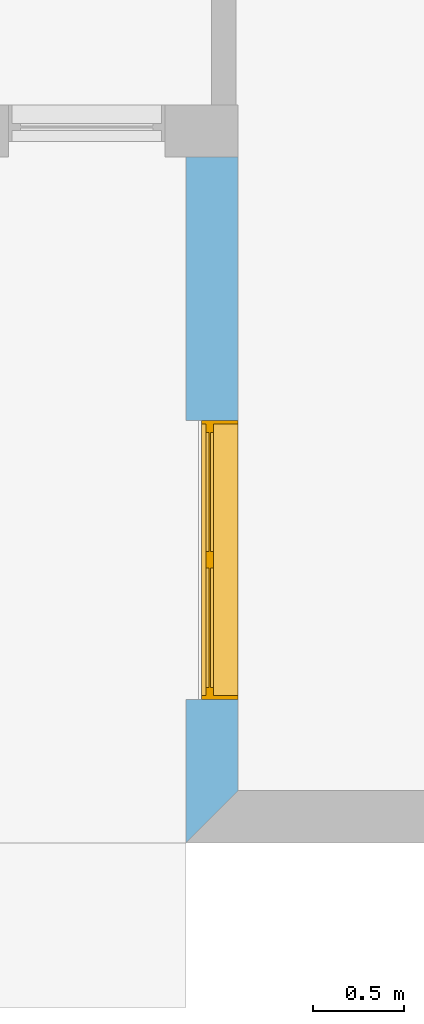
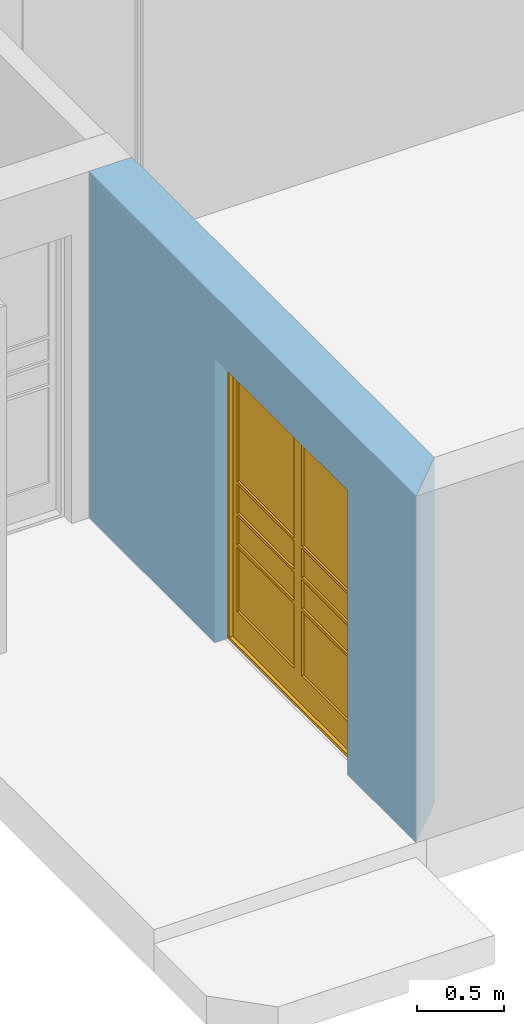
# One storey, part 8 of 15: 1 window, 1 opening, plus 1 element that does not belong to this part.
"""IFC4 building model written with IfcOpenShell, lengths in millimetres."""

from ifc_helpers import new_model, entity, si_unit, converted_unit, frame, origin_with_axes, origin_2d_with_axis, place, context, subcontext, project, spatial, line, indexed_curve, outline, extrude, clip, halfspace, polygons, source, transform, mapped, material, layer, layer_set, layer_usage, type_object, type_shapes, element, fill, save


model = new_model("IFC4")

# Units and contexts
model_context = context("Model", 3, precision=1e-05, world=origin_with_axes())
plan_context = context("Plan", 2, precision=1e-05, world=origin_2d_with_axis())
body_context = subcontext(model_context, "Body", "Model", "MODEL_VIEW")
ifc_project = project(units=[si_unit("VOLUMEUNIT", "CUBIC_METRE"), si_unit("LENGTHUNIT", "METRE", prefix="MILLI"), converted_unit("PLANEANGLEUNIT", "degree", entity("IfcReal", 0.0174532925199433), si_unit("PLANEANGLEUNIT", "RADIAN"), dimensions=[0, 0, 0, 0, 0, 0, 0]), si_unit("AREAUNIT", "SQUARE_METRE")], contexts=[model_context, plan_context])

# Site, building, storey
site_placement = place(None, origin_with_axes())
site = spatial("IfcSite", under=ifc_project, at=site_placement)
building_placement = place(site_placement, origin_with_axes())
building = spatial("IfcBuilding", under=site, at=building_placement, Name="Building")
storey_placement = place(building_placement, origin_with_axes())
storey = spatial("IfcBuildingStorey", under=building, at=storey_placement, Name="EXISTING")

# Wall, opening, window
ifc_material = material()
ifc_layer = layer(ifc_material, 285.0, Name="brick")
ifc_layer_set = layer_set([ifc_layer])
ifc_layer_usage = layer_usage(ifc_layer_set, "AXIS2", "POSITIVE", 0.0)
wall_type = type_object("IfcWallType", Name="285mm Wall", PredefinedType="STANDARD", material=ifc_layer_set)
wall_placement = place(storey_placement, frame((5879.11891937256, -4518.33343505859, 0.0), z_axis=(0.0, 0.0, 1.0), x_axis=(3.13916473260163e-07, 0.999999999999951, 0.0)))
wall = element("IfcWall", 1, at=wall_placement, inside=storey, type_object=wall_type, material=ifc_layer_usage, Name="Wall", context=body_context, shape_type="Clipping", body=[
    clip(extrude(outline(indexed_curve([(0.0, 0.0), (0.0, 285.0), (3750.00025431326, 285.0), (3750.00025431326, 0.0), (0.0, 0.0)], self_intersect=False)), origin_with_axes(), (0.0, 0.0, 1.0), 2425.00019073486), halfspace(frame((285.000115633011, -0.000329928298015147, 0.0), z_axis=(-0.707106828689575, -0.707106709480286, 0.0), x_axis=(-0.707106721581899, 0.707106840791191, 0.0)), False)),
])
shared_shape_1 = source(origin_with_axes(), body_context, "Body", "SweptSolid", [
    extrude(outline(indexed_curve([(0.0, 0.0), (1525.00061035156, 0.0), (1525.00061035156, 1989.99975585938), (0.0, 1989.99975585938)], segments=[line(1, 2, 3, 4, 1)])), frame((-3.27825517842939e-07, -600.0, 0.0), z_axis=(0.0, -1.0, 0.0), x_axis=(1.0, 0.0, 0.0)), (0.0, 0.0, -1.0), 1200.0),
])
opening_placement = place(wall_placement, frame((785.000324249383, -0.000230412628532406, 0.0), z_axis=(0.0, 0.0, 1.0), x_axis=(1.0, -5.29395592033938e-23, 0.0)))
opening = element("IfcOpeningElement", 2, at=opening_placement, cuts=wall, PredefinedType="OPENING", context=body_context, shape_type="MappedRepresentation", body=[
    mapped(shared_shape_1, transform((0.0, 0.0, 0.0), x_axis=(1.0, 0.0, 0.0), y_axis=(0.0, 1.0, 0.0), z_axis=(0.0, 0.0, 1.0), scale=1.0)),
])
window_type = type_object("IfcWindowType", Name="Ex.1525x1990", PartitioningType="NOTDEFINED", PredefinedType="WINDOW")
shared_shape_2 = source(origin_with_axes(), body_context, "Body", "Tessellation", [
    polygons([(1525.00012207031, -146.538314819336, 0.0), (1525.00012207031, -146.538314819336, 19.999979019165), (0.000149011597386561, -146.538543701172, 0.0), (0.000149011597386561, -146.538543701172, 19.999979019165), (1525.00012207031, 53.4614906311035, 0.0), (1525.00012207031, 53.4614906311035, 19.999979019165), (0.000149011597386561, 53.4614906311035, 0.0), (0.000149011597386561, 53.4614906311035, 19.999979019165), (-0.000327825517160818, -146.538314819336, 19.999979019165), (19.9996509552002, -146.538314819336, 19.999979019165), (-0.000327825517160818, -146.538543701172, 1969.99987792969), (19.9996509552002, -146.538543701172, 1969.99987792969), (-0.000327825517160818, 53.4614906311035, 19.999979019165), (19.9996509552002, 53.4614906311035, 19.999979019165), (-0.000327825517160818, 53.4614906311035, 1969.99987792969), (19.9996509552002, 53.4614906311035, 1969.99987792969), (1505.00036621094, -146.538314819336, 19.999979019165), (1525.00036621094, -146.538314819336, 19.999979019165), (1504.99987792969, -146.538543701172, 1969.99987792969), (1525.00012207031, -146.538543701172, 1969.99987792969), (1505.00012207031, 53.4614906311035, 19.999979019165), (1525.00036621094, 53.4614906311035, 19.999979019165), (1504.99987792969, 53.4614906311035, 1969.99987792969), (1524.99987792969, 53.4614906311035, 1969.99987792969), (1525.00012207031, -146.538314819336, 1969.99987792969), (1525.00012207031, -146.538314819336, 1989.99987792969), (0.000149011597386561, -146.538543701172, 1969.99987792969), (0.000149011597386561, -146.538543701172, 1989.99987792969), (1525.00012207031, 53.4614906311035, 1969.99987792969), (1525.00012207031, 53.4614906311035, 1989.99987792969), (0.000149011597386561, 53.4614906311035, 1969.99987792969), (0.000149011597386561, 53.4614906311035, 1989.99987792969), (64.9987716674805, -11.5385608673096, 1925.00061035156), (19.999174118042, -11.5385608673096, 1925.00061035156), (64.9987716674805, -11.5385608673096, 220.002517700195), (19.999174118042, -11.5383224487305, 220.002517700195), (64.9987716674805, 28.4616374969482, 1925.00061035156), (19.999174118042, 28.4616374969482, 1925.00061035156), (64.9987716674805, 28.4616374969482, 220.002517700195), (19.999174118042, 28.4616374969482, 220.002517700195), (762.499389648438, -11.5383224487305, 20.0024242401123), (762.499389648438, -11.5383224487305, 220.001449584961), (20.0001277923584, -11.5383224487305, 20.0034370422363), (20.0001277923584, -11.5383224487305, 220.002395629883), (762.499389648438, 28.4616374969482, 20.0024242401123), (762.499389648438, 28.4616374969482, 220.001449584961), (20.0001277923584, 28.4616374969482, 20.0034370422363), (20.0001277923584, 28.4616374969482, 220.002395629883), (1504.99987792969, -11.5385608673096, 1925.00036621094), (1460.00048828125, -11.5385608673096, 1925.00036621094), (1504.99963378906, -11.5385608673096, 220.00227355957), (1460.00036621094, -11.5383224487305, 220.00227355957), (1504.99987792969, 28.4616374969482, 1925.00036621094), (1460.00048828125, 28.4616374969482, 1925.00036621094), (1504.99963378906, 28.4616374969482, 220.00227355957), (1460.00036621094, 28.4616374969482, 220.00227355957), (762.499389648438, -11.5385608673096, 1925.00036621094), (717.499816894531, -11.5385608673096, 1925.00036621094), (762.499389648438, -11.5385608673096, 220.002395629883), (717.499816894531, -11.5383224487305, 220.002395629883), (762.499389648438, 28.4616374969482, 1925.00036621094), (717.499816894531, 28.4616374969482, 1925.00036621094), (762.499389648438, 28.4616374969482, 220.002395629883), (717.499816894531, 28.4616374969482, 220.002395629883), (807.499450683594, -11.5385608673096, 1925.00036621094), (762.500366210938, -11.5385608673096, 1925.00036621094), (807.499450683594, -11.5385608673096, 220.002395629883), (762.500366210938, -11.5383224487305, 220.002395629883), (807.499450683594, 28.4616374969482, 1925.00036621094), (762.500366210938, 28.4616374969482, 1925.00036621094), (807.499450683594, 28.4616374969482, 220.002395629883), (762.500366210938, 28.4616374969482, 220.002395629883), (1504.99963378906, -11.5383224487305, 20.0024242401123), (1504.99963378906, -11.5383224487305, 220.001449584961), (762.500854492188, -11.5383224487305, 20.0034370422363), (762.500854492188, -11.5383224487305, 220.002395629883), (1504.99963378906, 28.4616374969482, 20.0024242401123), (1504.99963378906, 28.4616374969482, 220.001449584961), (762.500854492188, 28.4616374969482, 20.0034370422363), (762.500854492188, 28.4616374969482, 220.002395629883), (762.499389648438, -11.5383224487305, 1924.99938964844), (762.499389648438, -11.5383224487305, 1969.99890136719), (20.0001277923584, -11.5383224487305, 1925.00036621094), (20.0001277923584, -11.5383224487305, 1969.99987792969), (762.499389648438, 28.4616374969482, 1924.99938964844), (762.499389648438, 28.4616374969482, 1969.99890136719), (20.0001277923584, 28.4616374969482, 1925.00036621094), (20.0001277923584, 28.4616374969482, 1969.99987792969), (1504.99963378906, -11.5383224487305, 1924.99938964844), (1504.99963378906, -11.5383224487305, 1969.99890136719), (762.500854492188, -11.5383224487305, 1925.00036621094), (762.500854492188, -11.5383224487305, 1969.99987792969), (1504.99963378906, 28.4616374969482, 1924.99938964844), (1504.99963378906, 28.4616374969482, 1969.99890136719), (762.500854492188, 28.4616374969482, 1925.00036621094), (762.500854492188, 28.4616374969482, 1969.99987792969), (717.499816894531, -11.5383224487305, 1110.00158691406), (717.499816894531, -11.5383224487305, 1130.00109863281), (64.9987716674805, -11.5383224487305, 1110.001953125), (64.9987716674805, -11.5383224487305, 1130.00158691406), (717.499816894531, 28.4616374969482, 1110.00158691406), (717.499816894531, 28.4616374969482, 1130.00109863281), (64.9987716674805, 28.4616374969482, 1110.001953125), (64.9987716674805, 28.4616374969482, 1130.00158691406), (1460.00036621094, -11.5383224487305, 1110.00158691406), (1460.00036621094, -11.5383224487305, 1130.00109863281), (807.4990234375, -11.5383224487305, 1110.001953125), (807.4990234375, -11.5383224487305, 1130.00158691406), (1460.00036621094, 28.4616374969482, 1110.00158691406), (1460.00036621094, 28.4616374969482, 1130.00109863281), (807.4990234375, 28.4616374969482, 1110.001953125), (807.4990234375, 28.4616374969482, 1130.00158691406), (717.499816894531, -11.5383224487305, 890.001708984375), (717.499816894531, -11.5383224487305, 910.001220703125), (64.9987716674805, -11.5383224487305, 890.001953125), (64.9987716674805, -11.5383224487305, 910.001708984375), (717.499816894531, 28.4616374969482, 890.001708984375), (717.499816894531, 28.4616374969482, 910.001220703125), (64.9987716674805, 28.4616374969482, 890.001953125), (64.9987716674805, 28.4616374969482, 910.001708984375), (1460.00036621094, -11.5383224487305, 890.001708984375), (1460.00036621094, -11.5383224487305, 910.001220703125), (807.4990234375, -11.5383224487305, 890.001953125), (807.4990234375, -11.5383224487305, 910.001708984375), (1460.00036621094, 28.4616374969482, 890.001708984375), (1460.00036621094, 28.4616374969482, 910.001220703125), (807.4990234375, 28.4616374969482, 890.001953125), (807.4990234375, 28.4616374969482, 910.001708984375), (717.499816894531, -11.5383224487305, 670.001586914062), (717.499816894531, -11.5383224487305, 690.001159667969), (64.9987716674805, -11.5383224487305, 670.002014160156), (64.9987716674805, -11.5383224487305, 690.001586914062), (717.499816894531, 28.4616374969482, 670.001586914062), (717.499816894531, 28.4616374969482, 690.001159667969), (64.9987716674805, 28.4616374969482, 670.002014160156), (64.9987716674805, 28.4616374969482, 690.001586914062), (1460.00036621094, -11.5383224487305, 670.001586914062), (1460.00036621094, -11.5383224487305, 690.001159667969), (807.4990234375, -11.5383224487305, 670.002014160156), (807.4990234375, -11.5383224487305, 690.001586914062), (1460.00036621094, 28.4616374969482, 670.001586914062), (1460.00036621094, 28.4616374969482, 690.001159667969), (807.4990234375, 28.4616374969482, 670.002014160156), (807.4990234375, 28.4616374969482, 690.001586914062), (717.499328613281, 3.4615433216095, 1925.00036621094), (64.9987716674805, 3.4615433216095, 1925.00036621094), (717.499328613281, 3.4615433216095, 1130.00122070312), (64.9987716674805, 3.4615433216095, 1130.00122070312), (717.499328613281, 13.4615335464478, 1925.00036621094), (64.9987716674805, 13.4615335464478, 1925.00036621094), (717.499328613281, 13.4615335464478, 1130.00122070312), (64.9987716674805, 13.4615335464478, 1130.00122070312), (717.499328613281, 3.4615433216095, 670.001831054688), (64.9987716674805, 3.4615433216095, 670.001831054688), (717.499328613281, 3.4615433216095, 220.001983642578), (64.9987716674805, 3.4615433216095, 220.002044677734), (717.499328613281, 13.4615335464478, 670.001831054688), (64.9987716674805, 13.4615335464478, 670.001831054688), (717.499328613281, 13.4615335464478, 220.001983642578), (64.9987716674805, 13.4615335464478, 220.002044677734), (717.499328613281, 3.4615433216095, 1110.00158691406), (64.9987716674805, 3.4615433216095, 1110.00158691406), (717.499328613281, 3.4615433216095, 910.001220703125), (64.9987716674805, 3.4615433216095, 910.001220703125), (717.499328613281, 13.4615335464478, 1110.00158691406), (64.9987716674805, 13.4615335464478, 1110.00158691406), (717.499328613281, 13.4615335464478, 910.001220703125), (64.9987716674805, 13.4615335464478, 910.001220703125), (717.499328613281, 3.4615433216095, 890.002197265625), (64.9987716674805, 3.4615433216095, 890.002197265625), (717.499328613281, 3.4615433216095, 690.001831054688), (64.9987716674805, 3.4615433216095, 690.001831054688), (717.499328613281, 13.4615335464478, 890.002197265625), (64.9987716674805, 13.4615335464478, 890.002197265625), (717.499328613281, 13.4615335464478, 690.001831054688), (64.9987716674805, 13.4615335464478, 690.001831054688), (1459.99987792969, 3.4615433216095, 1925.00036621094), (807.499450683594, 3.4615433216095, 1925.00036621094), (1459.99987792969, 3.4615433216095, 1130.00122070312), (807.4990234375, 3.4615433216095, 1130.00122070312), (1459.99987792969, 13.4615335464478, 1925.00036621094), (807.499450683594, 13.4615335464478, 1925.00036621094), (1459.99987792969, 13.4615335464478, 1130.00122070312), (807.4990234375, 13.4615335464478, 1130.00122070312), (1459.99987792969, 3.4615433216095, 670.001831054688), (807.499450683594, 3.4615433216095, 670.001831054688), (1459.99987792969, 3.4615433216095, 220.001983642578), (807.4990234375, 3.4615433216095, 220.002044677734), (1459.99987792969, 13.4615335464478, 670.001831054688), (807.499450683594, 13.4615335464478, 670.001831054688), (1459.99987792969, 13.4615335464478, 220.001983642578), (807.4990234375, 13.4615335464478, 220.002044677734), (1459.99987792969, 3.4615433216095, 1110.00158691406), (807.499450683594, 3.4615433216095, 1110.00158691406), (1459.99987792969, 3.4615433216095, 910.001220703125), (807.4990234375, 3.4615433216095, 910.001220703125), (1459.99987792969, 13.4615335464478, 1110.00158691406), (807.499450683594, 13.4615335464478, 1110.00158691406), (1459.99987792969, 13.4615335464478, 910.001220703125), (807.4990234375, 13.4615335464478, 910.001220703125), (1459.99987792969, 3.4615433216095, 890.002197265625), (807.499450683594, 3.4615433216095, 890.002197265625), (1459.99987792969, 3.4615433216095, 690.001831054688), (807.4990234375, 3.4615433216095, 690.001831054688), (1459.99987792969, 13.4615335464478, 890.002197265625), (807.499450683594, 13.4615335464478, 890.002197265625), (1459.99987792969, 13.4615335464478, 690.001831054688), (807.4990234375, 13.4615335464478, 690.001831054688)], [[[1, 2, 4, 3]], [[3, 4, 8, 7]], [[7, 8, 6, 5]], [[5, 6, 2, 1]], [[3, 7, 5, 1]], [[8, 4, 2, 6]], [[9, 10, 12, 11]], [[11, 12, 16, 15]], [[15, 16, 14, 13]], [[13, 14, 10, 9]], [[11, 15, 13, 9]], [[16, 12, 10, 14]], [[17, 18, 20, 19]], [[19, 20, 24, 23]], [[23, 24, 22, 21]], [[21, 22, 18, 17]], [[19, 23, 21, 17]], [[24, 20, 18, 22]], [[25, 26, 28, 27]], [[27, 28, 32, 31]], [[31, 32, 30, 29]], [[29, 30, 26, 25]], [[27, 31, 29, 25]], [[32, 28, 26, 30]], [[33, 34, 36, 35]], [[35, 36, 40, 39]], [[39, 40, 38, 37]], [[37, 38, 34, 33]], [[35, 39, 37, 33]], [[40, 36, 34, 38]], [[41, 42, 44, 43]], [[43, 44, 48, 47]], [[47, 48, 46, 45]], [[45, 46, 42, 41]], [[43, 47, 45, 41]], [[48, 44, 42, 46]], [[49, 50, 52, 51]], [[51, 52, 56, 55]], [[55, 56, 54, 53]], [[53, 54, 50, 49]], [[51, 55, 53, 49]], [[56, 52, 50, 54]], [[57, 58, 60, 59]], [[59, 60, 64, 63]], [[63, 64, 62, 61]], [[61, 62, 58, 57]], [[59, 63, 61, 57]], [[64, 60, 58, 62]], [[65, 66, 68, 67]], [[67, 68, 72, 71]], [[71, 72, 70, 69]], [[69, 70, 66, 65]], [[67, 71, 69, 65]], [[72, 68, 66, 70]], [[73, 74, 76, 75]], [[75, 76, 80, 79]], [[79, 80, 78, 77]], [[77, 78, 74, 73]], [[75, 79, 77, 73]], [[80, 76, 74, 78]], [[81, 82, 84, 83]], [[83, 84, 88, 87]], [[87, 88, 86, 85]], [[85, 86, 82, 81]], [[83, 87, 85, 81]], [[88, 84, 82, 86]], [[89, 90, 92, 91]], [[91, 92, 96, 95]], [[95, 96, 94, 93]], [[93, 94, 90, 89]], [[91, 95, 93, 89]], [[96, 92, 90, 94]], [[97, 98, 100, 99]], [[99, 100, 104, 103]], [[103, 104, 102, 101]], [[101, 102, 98, 97]], [[99, 103, 101, 97]], [[104, 100, 98, 102]], [[105, 106, 108, 107]], [[107, 108, 112, 111]], [[111, 112, 110, 109]], [[109, 110, 106, 105]], [[107, 111, 109, 105]], [[112, 108, 106, 110]], [[113, 114, 116, 115]], [[115, 116, 120, 119]], [[119, 120, 118, 117]], [[117, 118, 114, 113]], [[115, 119, 117, 113]], [[120, 116, 114, 118]], [[121, 122, 124, 123]], [[123, 124, 128, 127]], [[127, 128, 126, 125]], [[125, 126, 122, 121]], [[123, 127, 125, 121]], [[128, 124, 122, 126]], [[129, 130, 132, 131]], [[131, 132, 136, 135]], [[135, 136, 134, 133]], [[133, 134, 130, 129]], [[131, 135, 133, 129]], [[136, 132, 130, 134]], [[137, 138, 140, 139]], [[139, 140, 144, 143]], [[143, 144, 142, 141]], [[141, 142, 138, 137]], [[139, 143, 141, 137]], [[144, 140, 138, 142]], [[145, 146, 148, 147]], [[147, 148, 152, 151]], [[151, 152, 150, 149]], [[149, 150, 146, 145]], [[147, 151, 149, 145]], [[152, 148, 146, 150]], [[153, 154, 156, 155]], [[155, 156, 160, 159]], [[159, 160, 158, 157]], [[157, 158, 154, 153]], [[155, 159, 157, 153]], [[160, 156, 154, 158]], [[161, 162, 164, 163]], [[163, 164, 168, 167]], [[167, 168, 166, 165]], [[165, 166, 162, 161]], [[163, 167, 165, 161]], [[168, 164, 162, 166]], [[169, 170, 172, 171]], [[171, 172, 176, 175]], [[175, 176, 174, 173]], [[173, 174, 170, 169]], [[171, 175, 173, 169]], [[176, 172, 170, 174]], [[177, 178, 180, 179]], [[179, 180, 184, 183]], [[183, 184, 182, 181]], [[181, 182, 178, 177]], [[179, 183, 181, 177]], [[184, 180, 178, 182]], [[185, 186, 188, 187]], [[187, 188, 192, 191]], [[191, 192, 190, 189]], [[189, 190, 186, 185]], [[187, 191, 189, 185]], [[192, 188, 186, 190]], [[193, 194, 196, 195]], [[195, 196, 200, 199]], [[199, 200, 198, 197]], [[197, 198, 194, 193]], [[195, 199, 197, 193]], [[200, 196, 194, 198]], [[201, 202, 204, 203]], [[203, 204, 208, 207]], [[207, 208, 206, 205]], [[205, 206, 202, 201]], [[203, 207, 205, 201]], [[208, 204, 202, 206]]], closed=True),
])
type_shapes(window_type, [shared_shape_2])
window_placement = place(opening_placement, frame((-0.000522838235372802, 146.53921127304, 0.0), z_axis=(0.0, 0.0, 1.0), x_axis=(1.0, 5.29395592033938e-23, 0.0)))
window = element("IfcWindow", 3, at=window_placement, inside=storey, type_object=window_type, Name="Window", context=body_context, shape_type="MappedRepresentation", body=[
    mapped(shared_shape_2, transform((0.0, 0.0, 0.0), x_axis=(1.0, 0.0, 0.0), y_axis=(0.0, 1.0, 0.0), z_axis=(0.0, 0.0, 1.0), scale=1.0)),
])
fill(opening, window)

save(model, "model.ifc")
